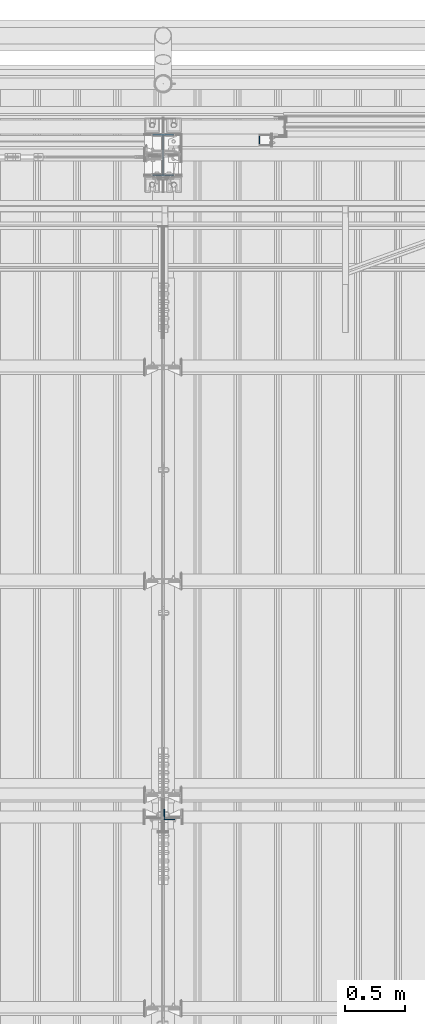
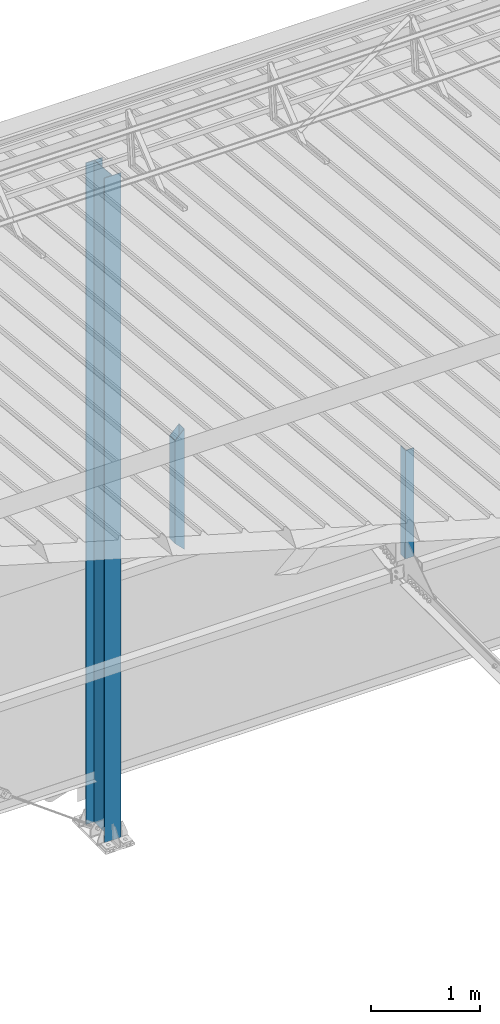
# One storey, part 233 of 709: 3 columns, 3 elements without a shape of their own.
"""IFC4 building model written with IfcOpenShell, lengths in millimetres."""

from ifc_helpers import new_model, si_unit, direction, frame, origin_with_axes, place, context, subcontext, project, spatial, polygons, material, element, aggregate, save


model = new_model("IFC4")

# Units and contexts
model_context = context("Model", 3, precision=0.2, world=origin_with_axes(), true_north=direction((0.0, 1.0)))
body_context = subcontext(model_context, "Body", "Model", "MODEL_VIEW")
ifc_project = project(units=[si_unit("LENGTHUNIT", "METRE", prefix="MILLI"), si_unit("AREAUNIT", "SQUARE_METRE"), si_unit("VOLUMEUNIT", "CUBIC_METRE"), si_unit("MASSUNIT", "GRAM", prefix="KILO"), si_unit("TIMEUNIT", "SECOND"), si_unit("PLANEANGLEUNIT", "RADIAN"), si_unit("SOLIDANGLEUNIT", "STERADIAN"), si_unit("THERMODYNAMICTEMPERATUREUNIT", "DEGREE_CELSIUS"), si_unit("LUMINOUSINTENSITYUNIT", "LUMEN")], contexts=[model_context])

# Site, building, storey
site_placement = place(None, origin_with_axes())
site = spatial("IfcSite", under=ifc_project, at=site_placement, CompositionType="ELEMENT")
building_placement = place(site_placement, origin_with_axes())
building = spatial("IfcBuilding", under=site, at=building_placement, Name="Undefined", CompositionType="ELEMENT")
storey_placement = place(building_placement, origin_with_axes())
storey = spatial("IfcBuildingStorey", under=building, at=storey_placement, Name="Undefined", CompositionType="ELEMENT", Elevation=0.0)

# Assembly, column
assembly_1_placement = place(storey_placement, frame((28051.0, 16347.7, 6024.30002), z_axis=(0.0, 1.0, 0.0), x_axis=(0.0, 0.0, 1.0)))
assembly_1 = element("IfcElementAssembly", 1, at=assembly_1_placement, inside=storey)
ifc_material_1 = material(Name="C345-5", Category="STEEL")
column_1_placement = place(assembly_1_placement, origin_with_axes())
column_1 = element("IfcColumn", 2, at=column_1_placement, material=ifc_material_1, ObjectType="436", context=body_context, shape_type="Tessellation", body=[
    polygons([(185.7, -45.0, -45.0), (185.7, 45.0, -45.0), (1399.4109, 45.0, -45.0), (1399.4109, -45.0, -45.0), (185.7, 45.0, -39.0), (1399.4109, 45.0, -39.0), (185.7, -39.0, -39.0), (1399.4109, -39.0, -39.0), (185.7, -39.0, 45.0), (1399.4109, -39.0, 45.0), (185.7, -45.0, 45.0), (1399.4109, -45.0, 45.0)], [[[1, 2, 3, 4]], [[2, 5, 6, 3]], [[5, 7, 8, 6]], [[7, 9, 10, 8]], [[9, 11, 12, 10]], [[11, 1, 4, 12]], [[6, 8, 10, 12, 4, 3]], [[11, 9, 7, 5, 2, 1]]], closed=True),
])
aggregate(assembly_1, [column_1])

assembly_2_placement = place(storey_placement, frame((28850.0, 21950.0, 2600.0), z_axis=(-1.0, 0.0, 0.0), x_axis=(0.0, 0.0, 1.0)))
assembly_2 = element("IfcElementAssembly", 3, at=assembly_2_placement, inside=storey)
ifc_material_2 = material(Name="C355", Category="STEEL")
column_2_placement = place(assembly_2_placement, origin_with_axes())
column_2 = element("IfcColumn", 4, at=column_2_placement, material=ifc_material_2, ObjectType="493", context=body_context, shape_type="Tessellation", body=[
    polygons([(10.0, -50.0, -50.0), (10.0, 50.0, -50.0), (1360.0, 50.0, -50.0), (1360.0, -50.0, -50.0), (110.0, -50.0, 50.0), (1260.0, -50.0, 50.0), (110.0, 50.0, 50.0), (1260.0, 50.0, 50.0), (107.0, 47.0, 47.0), (13.0, 47.0, -47.0), (1357.0, 47.0, -47.0), (1263.0, 47.0, 47.0), (107.0, -47.0, 47.0), (1263.0, -47.0, 47.0), (13.0, -47.0, -47.0), (1357.0, -47.0, -47.0)], [[[1, 2, 3, 4]], [[5, 1, 4, 6]], [[7, 5, 6, 8]], [[2, 7, 8, 3]], [[1, 5, 7, 2], [15, 10, 9, 13]], [[9, 10, 11, 12]], [[13, 9, 12, 14]], [[15, 13, 14, 16]], [[10, 15, 16, 11]], [[6, 4, 3, 8], [14, 12, 11, 16]]], closed=True),
])
aggregate(assembly_2, [column_2])

assembly_3_placement = place(storey_placement, frame((28000.0, 21827.0, -200.0), z_axis=(-1.0, 0.0, 0.0), x_axis=(0.0, 0.0, 1.0)))
assembly_3 = element("IfcElementAssembly", 5, at=assembly_3_placement, inside=storey)
ifc_material_3 = material(Name="C355-5", Category="STEEL")
column_3_placement = place(assembly_3_placement, origin_with_axes())
column_3 = element("IfcColumn", 6, at=column_3_placement, material=ifc_material_3, ObjectType="413", context=body_context, shape_type="Tessellation", body=[
    polygons([(25.0, -173.0, -87.0), (25.0, -164.0, -87.0), (7454.62297, -164.0, -87.0), (7455.52297, -173.0, -87.0), (25.0, -164.0, -3.0), (7454.62297, -164.0, -3.0), (25.0, 164.0, -3.0), (7421.82297, 164.0, -3.0), (25.0, 164.0, -87.0), (7421.82297, 164.0, -87.0), (25.0, 173.0, -87.0), (7420.92297, 173.0, -87.0), (25.0, 173.0, 87.0), (7420.92297, 173.0, 87.0), (25.0, 164.0, 87.0), (7421.82297, 164.0, 87.0), (25.0, 164.0, 3.0), (7421.82297, 164.0, 3.0), (25.0, -164.0, 3.0), (7454.62297, -164.0, 3.0), (25.0, -164.0, 87.0), (7454.62297, -164.0, 87.0), (25.0, -173.0, 87.0), (7455.52297, -173.0, 87.0)], [[[1, 2, 3, 4]], [[2, 5, 6, 3]], [[5, 7, 8, 6]], [[7, 9, 10, 8]], [[9, 11, 12, 10]], [[11, 13, 14, 12]], [[13, 15, 16, 14]], [[15, 17, 18, 16]], [[17, 19, 20, 18]], [[19, 21, 22, 20]], [[21, 23, 24, 22]], [[23, 1, 4, 24]], [[6, 8, 10, 12, 14, 16, 18, 20, 22, 24, 4, 3]], [[23, 21, 19, 17, 15, 13, 11, 9, 7, 5, 2, 1]]], closed=True),
])
aggregate(assembly_3, [column_3])

save(model, "model.ifc")
